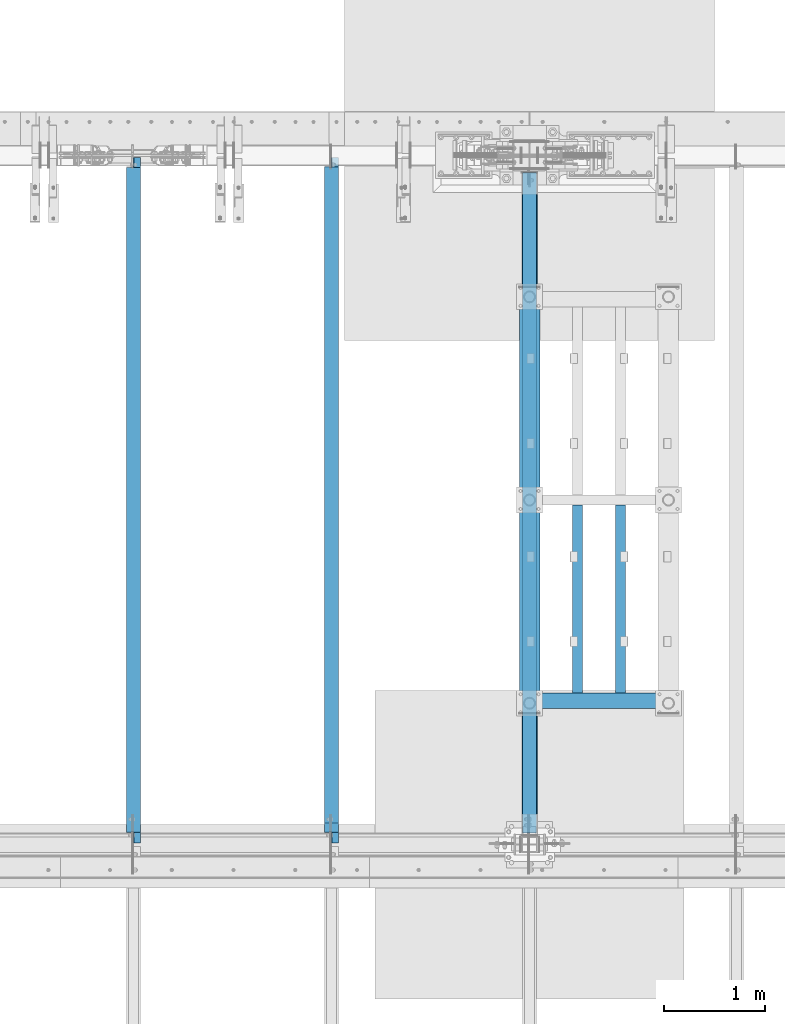
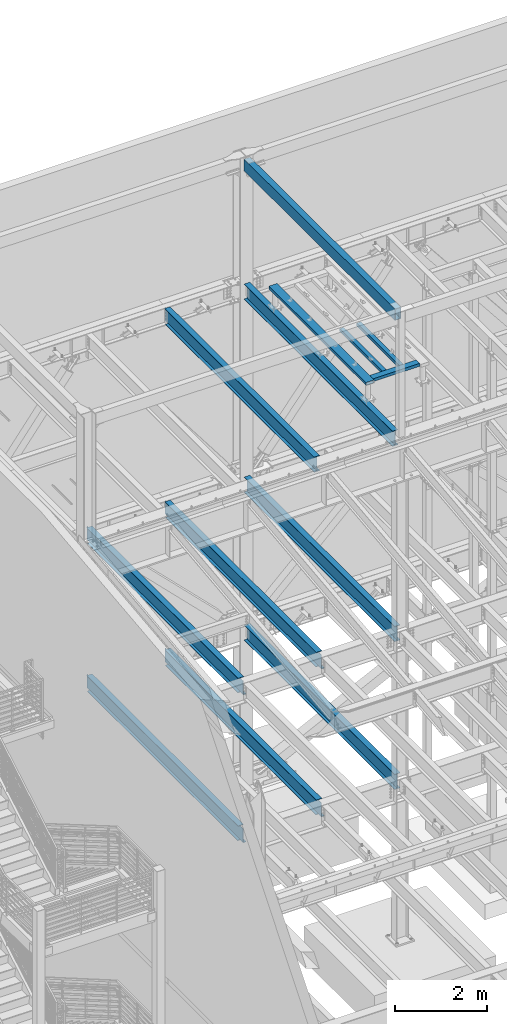
# One storey, part 767 of 1179: 13 beams, 10 elements without a shape of their own.
"""IFC2X3 building model written with IfcOpenShell, lengths in millimetres."""

from ifc_helpers import new_model, si_unit, frame, origin_with_axes, place, context, subcontext, project, spatial, faceted_brep, material, type_object, element, aggregate, save


model = new_model("IFC2X3")

# Units and contexts
model_context = context("Model", 3, precision=1e-05, world=origin_with_axes())
body_context = subcontext(model_context, "Body", "Model", "MODEL_VIEW")
ifc_project = project(units=[si_unit("LENGTHUNIT", "METRE", prefix="MILLI"), si_unit("AREAUNIT", "SQUARE_METRE"), si_unit("VOLUMEUNIT", "CUBIC_METRE"), si_unit("MASSUNIT", "GRAM", prefix="KILO"), si_unit("TIMEUNIT", "SECOND"), si_unit("PLANEANGLEUNIT", "RADIAN"), si_unit("SOLIDANGLEUNIT", "STERADIAN"), si_unit("THERMODYNAMICTEMPERATUREUNIT", "DEGREE_CELSIUS"), si_unit("LUMINOUSINTENSITYUNIT", "LUMEN")], contexts=[model_context])

# Site, building, storey
site_placement = place(None, origin_with_axes())
site = spatial("IfcSite", under=ifc_project, at=site_placement, CompositionType="ELEMENT")
building_placement = place(site_placement, origin_with_axes())
building = spatial("IfcBuilding", under=site, at=building_placement, Name="Undefined", CompositionType="ELEMENT")
storey_placement = place(building_placement, origin_with_axes())
storey = spatial("IfcBuildingStorey", under=building, at=storey_placement, Name="Undefined", CompositionType="ELEMENT", Elevation=0.0)

# Assembly, beam
assembly_1_placement = place(storey_placement, origin_with_axes())
assembly_1 = element("IfcElementAssembly", 1, at=assembly_1_placement, inside=storey, Name="BEAM", AssemblyPlace="NOTDEFINED", PredefinedType="RIGID_FRAME")
ifc_material_1 = material(Name="STEEL/A992")
beam_type_1 = type_object("IfcBeamType", Name="W16X31", PredefinedType="NOTDEFINED")
beam_1_placement = place(assembly_1_placement, frame((8280.4, 34391.6, 12917.4875), z_axis=(0.0, 0.0, 1.0), x_axis=(0.0, 1.0, 0.0)))
beam_1 = element("IfcBeam", 2, at=beam_1_placement, type_object=beam_type_1, material=ifc_material_1, Name="BEAM", ObjectType="W16X31", context=body_context, shape_type="Brep", body=[
    faceted_brep([(212.724999999999, -69.8499999999985, -201.612499999999), (212.724999999999, 69.8499999999985, -201.612499999999), (6637.33750000001, 69.8499999999985, -201.612499999999), (6637.33750000001, -69.8499999999985, -201.612499999999), (212.724999999999, -69.8499999999985, -190.5), (212.724999999999, -3.17499999999927, -190.5), (212.724999999999, -3.17499999999927, 190.5), (212.724999999999, -69.8499999999985, 190.5), (212.724999999999, -69.8499999999985, 201.612499999999), (212.724999999999, 69.8499999999985, 201.612499999999), (212.724999999999, 69.8499999999985, 190.5), (212.724999999999, 3.17499999999927, 190.5), (212.724999999999, 3.17499999999927, 162.664998864024), (212.724999999999, 3.17499999999927, -142.027500567505), (212.724999999999, 3.17499999999927, -190.5), (212.724999999999, 69.8499999999985, -190.5), (6637.33750000001, -69.8499999999985, -190.5), (6637.33750000001, -3.17499999999927, -190.5), (6637.33750000001, -3.17499999999927, 190.5), (6637.33750000001, -69.8499999999985, 190.5), (6637.33750000001, -69.8499999999985, 201.612499999999), (6637.33750000001, 69.8499999999985, 201.612499999999), (6637.33750000001, 69.8499999999985, 190.5), (6637.33750000001, 3.17499999999927, 190.5), (6637.33750000001, 3.17499999999927, -190.5), (6637.33750000001, 69.8499999999985, -190.5)], [[[0, 1, 2, 3]], [[0, 4, 5, 6, 7, 8, 9, 10, 11, 12, 13, 14, 15, 1]], [[5, 4, 16, 17]], [[6, 5, 17, 18]], [[7, 6, 18, 19]], [[8, 7, 19, 20]], [[9, 8, 20, 21]], [[10, 9, 21, 22]], [[11, 10, 22, 23]], [[14, 13, 12, 11, 23, 24]], [[15, 14, 24, 25]], [[1, 15, 25, 2]], [[24, 23, 22, 21, 20, 19, 18, 17, 16, 3, 2, 25]], [[4, 0, 3, 16]]]),
])
aggregate(assembly_1, [beam_1])

assembly_2_placement = place(storey_placement, origin_with_axes())
assembly_2 = element("IfcElementAssembly", 3, at=assembly_2_placement, inside=storey, Name="BEAM", AssemblyPlace="NOTDEFINED", PredefinedType="RIGID_FRAME")
beam_2_placement = place(assembly_2_placement, frame((6324.6, 34391.6, 12917.4875), z_axis=(0.0, 0.0, 1.0), x_axis=(0.0, 1.0, 0.0)))
beam_2 = element("IfcBeam", 4, at=beam_2_placement, type_object=beam_type_1, material=ifc_material_1, Name="BEAM", ObjectType="W16X31", context=body_context, shape_type="Brep", body=[
    faceted_brep([(212.724999999999, 69.8499999999985, -190.5), (212.724999999999, 3.17499999999927, -190.5), (6661.94375000001, 3.17499999999927, -190.5), (6661.94375000001, 69.8499999999985, -190.5), (212.724999999999, -3.17499999999927, -190.5), (212.724999999999, -69.8499999999985, -190.5), (6788.94375000001, -69.8499999999985, -190.5), (6788.94375000001, -3.17499999999927, -190.5), (212.724999999999, -69.8499999999985, -201.612499999999), (6788.94375000001, -69.8499999999985, -201.612499999999), (6788.94375000001, 3.17549991607666, -201.612499999999), (6788.94375000001, 3.17499999999927, -190.5), (6788.94375000001, 3.17499999999927, 163.512499999999), (6788.94375000001, -3.17499999999927, 163.512499999999), (6661.94375000001, 3.17549991607666, -201.612499999999), (212.724999999999, 69.8499999999985, -201.612499999999), (6661.94375000001, 69.8499999999985, -201.612499999999), (212.724999999999, -3.17499999999927, 190.5), (212.724999999999, -69.8499999999985, 190.5), (212.724999999999, -69.8499999999985, 201.612499999999), (212.724999999999, 69.8499999999985, 201.612499999999), (212.724999999999, 69.8499999999985, 190.5), (212.724999999999, 3.17499999999927, 190.5), (212.724999999999, 3.17499999999927, 162.664998864024), (212.724999999999, 3.17499999999927, -142.027500567505), (6696.86875000001, 69.8499999999985, 190.5), (6696.86875000001, 3.17499999999927, 190.5), (6696.86875000001, 3.17499999999927, 176.212499809264), (6697.8354799226, 3.17499999999927, 171.352420291218), (6700.58849382307, 3.17499999999927, 167.232243823064), (6704.70867029123, 3.17499999999927, 164.479229922586), (6709.56874980927, 3.17499999999927, 163.512499999999), (6697.8354799226, -3.17499999999927, 171.352420291218), (6696.86875000001, -3.17499999999927, 176.212499809264), (6700.58849382307, -3.17499999999927, 167.232243823064), (6704.70867029123, -3.17499999999927, 164.479229922586), (6709.56874980927, -3.17499999999927, 163.512499999999), (6696.86875000001, -3.17499999999927, 190.5), (6696.86875000001, -69.8499999999985, 190.5), (6696.86875000001, -69.8499999999985, 201.612499999999), (6696.86875000001, 69.8499999999985, 201.612499999999)], [[[0, 1, 2, 3]], [[4, 5, 6, 7]], [[5, 8, 9, 6]], [[7, 6, 9, 10, 11, 12, 13]], [[11, 10, 14, 2]], [[9, 8, 15, 16, 14, 10]], [[2, 14, 16, 3]], [[15, 0, 3, 16]], [[8, 5, 4, 17, 18, 19, 20, 21, 22, 23, 24, 1, 0, 15]], [[22, 21, 25, 26]], [[11, 2, 1, 24, 23, 22, 26, 27, 28, 29, 30, 31, 12]], [[32, 28, 27, 33]], [[34, 29, 28, 32]], [[35, 30, 29, 34]], [[36, 31, 30, 35]], [[13, 12, 31, 36]], [[35, 34, 32, 33, 37, 17, 4, 7, 13, 36]], [[18, 17, 37, 38]], [[19, 18, 38, 39]], [[20, 19, 39, 40]], [[21, 20, 40, 25]], [[39, 38, 37, 33, 27, 26, 25, 40]]]),
])
aggregate(assembly_2, [beam_2])

assembly_3_placement = place(storey_placement, origin_with_axes())
assembly_3 = element("IfcElementAssembly", 5, at=assembly_3_placement, inside=storey, Name="BEAM", AssemblyPlace="NOTDEFINED", PredefinedType="RIGID_FRAME")
beam_3_placement = place(assembly_3_placement, frame((8280.4, 34391.6, 7812.0875), z_axis=(0.0, 0.0, 1.0), x_axis=(0.0, 1.0, 0.0)))
beam_3 = element("IfcBeam", 6, at=beam_3_placement, type_object=beam_type_1, material=ifc_material_1, Name="BEAM", ObjectType="W16X31", context=body_context, shape_type="Brep", body=[
    faceted_brep([(115.887499999997, -69.8499999999985, -201.6125), (115.887499999997, 69.8499999999985, -201.6125), (6637.33750000001, 69.8499999999985, -201.612499999999), (6637.33750000001, -69.8499999999985, -201.612499999999), (115.887499999997, -69.8499999999985, -190.5), (115.887499999997, -3.17499999999927, -190.5), (115.887499999997, -3.17499999999927, 190.5), (115.887499999997, -69.8499999999985, 190.5), (115.887499999997, -69.8499999999985, 201.6125), (115.887499999997, 69.8499999999985, 201.6125), (115.887499999997, 69.8499999999985, 190.5), (115.887499999997, 3.17499999999927, 190.5), (115.887499999997, 3.17499999999927, 164.252489941818), (115.887499999997, 3.17499999999927, -142.027503290603), (115.887499999997, 3.17499999999927, -190.5), (115.887499999997, 69.8499999999985, -190.5), (6637.33750000001, -69.8499999999985, -190.5), (6637.33750000001, -3.17499999999927, -190.5), (6637.33750000001, -3.17499999999927, 190.5), (6637.33750000001, -69.8499999999985, 190.5), (6637.33750000001, -69.8499999999985, 201.612499999999), (6637.33750000001, 69.8499999999985, 201.612499999999), (6637.33750000001, 69.8499999999985, 190.5), (6637.33750000001, 3.17499999999927, 190.5), (6637.33750000001, 3.17499999999927, -190.5), (6637.33750000001, 69.8499999999985, -190.5)], [[[0, 1, 2, 3]], [[0, 4, 5, 6, 7, 8, 9, 10, 11, 12, 13, 14, 15, 1]], [[5, 4, 16, 17]], [[6, 5, 17, 18]], [[7, 6, 18, 19]], [[8, 7, 19, 20]], [[9, 8, 20, 21]], [[10, 9, 21, 22]], [[11, 10, 22, 23]], [[14, 13, 12, 11, 23, 24]], [[15, 14, 24, 25]], [[1, 15, 25, 2]], [[24, 23, 22, 21, 20, 19, 18, 17, 16, 3, 2, 25]], [[4, 0, 3, 16]]]),
])
aggregate(assembly_3, [beam_3])

assembly_4_placement = place(storey_placement, origin_with_axes())
assembly_4 = element("IfcElementAssembly", 7, at=assembly_4_placement, inside=storey, Name="BEAM", AssemblyPlace="NOTDEFINED", PredefinedType="RIGID_FRAME")
beam_4_placement = place(assembly_4_placement, frame((6324.6, 34391.6, 7812.0875), z_axis=(0.0, 0.0, 1.0), x_axis=(0.0, 1.0, 0.0)))
beam_4 = element("IfcBeam", 8, at=beam_4_placement, type_object=beam_type_1, material=ifc_material_1, Name="BEAM", ObjectType="W16X31", context=body_context, shape_type="Brep", body=[
    faceted_brep([(104.775000190733, -3.17499999999927, 166.6875), (104.775000190733, 3.17497120592088, 166.6875), (17.4624999999942, 3.17499999999927, 166.6875), (17.4624999999942, -3.17499999999927, 166.6875), (109.63507970878, -3.17499999999927, 167.654229922588), (109.63507970878, 3.17497058299341, 167.654229922588), (113.755256176933, -3.17499999999927, 170.407243823066), (113.755256176933, 3.17496880904946, 170.407243823066), (116.508270077407, -3.17499999999927, 174.52742029122), (116.508270077407, 3.17496615415439, 174.52742029122), (117.474999999999, -3.17499999999927, 179.387499809265), (117.474999999999, 3.17496302249128, 179.387499809265), (117.474999999999, -69.8499999999985, 201.6125), (117.474999999999, 69.8499999999985, 201.6125), (117.474999999999, 69.8499999999985, 190.5), (117.474999999999, 3.17499999999927, 190.5), (117.474999999999, -3.17499999999927, 190.5), (117.474999999999, -69.8499999999985, 190.5), (6660.35625, 3.17499999999927, -190.5), (6660.35625, 69.8500000000004, -190.5), (144.462499999994, 69.8499999999985, -190.5), (144.462499999994, 3.17549991607666, -190.5), (17.4624999999942, -3.17499999999927, -190.5), (17.4624999999942, -69.8499999999985, -190.5), (6787.35625, -69.8500000000004, -190.5), (6787.35625, -3.17499999999927, -190.5), (17.4624999999942, -69.8499999999985, -201.6125), (6787.35625, -69.8500000000004, -201.6125), (6660.35625, 69.8500000000004, -201.6125), (6660.35625, 3.17549991607484, -201.6125), (6787.35625, 3.17549991607484, -201.6125), (17.4624999999942, 3.17549991607666, -201.6125), (144.462499999994, 3.17549991607666, -201.6125), (144.462499999994, 69.8499999999985, -201.6125), (17.4624999999942, 3.17499999999927, -190.5), (6787.35625, 3.17499999999927, -190.5), (6787.35625, 3.17499999999927, 157.1625), (6787.35625, -3.17499999999927, 157.1625), (6700.04374980927, 3.17499999999927, 157.1625), (6700.04374980927, -3.17499999999927, 157.1625), (6695.18367029123, 3.17499999999927, 158.129229922588), (6695.18367029123, -3.17499999999927, 158.129229922588), (6691.06349382307, 3.17499999999927, 160.882243823066), (6691.06349382307, -3.17499999999927, 160.882243823066), (6688.31047992259, 3.17499999999927, 165.00242029122), (6688.31047992259, -3.17499999999927, 165.00242029122), (6687.34375000001, 3.17499999999927, 169.862499809266), (6687.34375000001, -3.17499999999927, 169.862499809266), (6687.34375000001, -69.8500000000004, 201.6125), (6687.34375000001, -69.8500000000004, 190.5), (6687.34375000001, -3.17499999999927, 190.5), (6687.34375000001, 3.17499999999927, 190.5), (6687.34375000001, 69.8500000000004, 190.5), (6687.34375000001, 69.8500000000004, 201.6125)], [[[0, 1, 2, 3]], [[4, 5, 1, 0]], [[6, 7, 5, 4]], [[8, 9, 7, 6]], [[10, 11, 9, 8]], [[12, 13, 14, 15, 11, 10, 16, 17]], [[18, 19, 20, 21]], [[22, 23, 24, 25]], [[23, 26, 27, 24]], [[28, 29, 30, 27, 26, 31, 32, 33]], [[21, 32, 31, 34]], [[20, 33, 32, 21]], [[19, 28, 33, 20]], [[18, 29, 28, 19]], [[35, 30, 29, 18]], [[25, 24, 27, 30, 35, 36, 37]], [[37, 36, 38, 39]], [[39, 38, 40, 41]], [[41, 40, 42, 43]], [[43, 42, 44, 45]], [[45, 44, 46, 47]], [[48, 49, 50, 47, 46, 51, 52, 53]], [[49, 48, 12, 17]], [[50, 49, 17, 16]], [[8, 6, 4, 0, 3, 22, 25, 37, 39, 41, 43, 45, 47, 50, 16, 10]], [[34, 31, 26, 23, 22, 3, 2]], [[51, 46, 44, 42, 40, 38, 36, 35, 18, 21, 34, 2, 1, 5, 7, 9, 11, 15]], [[52, 51, 15, 14]], [[53, 52, 14, 13]], [[48, 53, 13, 12]]]),
])
aggregate(assembly_4, [beam_4])

assembly_5_placement = place(storey_placement, origin_with_axes())
assembly_5 = element("IfcElementAssembly", 9, at=assembly_5_placement, inside=storey, Name="BEAM", AssemblyPlace="NOTDEFINED", PredefinedType="RIGID_FRAME")
beam_5_placement = place(assembly_5_placement, frame((4368.8, 34391.6, 7812.0875), z_axis=(0.0, 0.0, 1.0), x_axis=(0.0, 1.0, 0.0)))
beam_5 = element("IfcBeam", 10, at=beam_5_placement, type_object=beam_type_1, material=ifc_material_1, Name="BEAM", ObjectType="W16X31", context=body_context, shape_type="Brep", body=[
    faceted_brep([(104.775000190733, -3.17499999999927, 166.6875), (104.775000190733, 3.17497120592088, 166.6875), (17.4624999999942, 3.17499999999927, 166.6875), (17.4624999999942, -3.17499999999927, 166.6875), (109.63507970878, -3.17499999999927, 167.654229922588), (109.63507970878, 3.17497058299341, 167.654229922588), (113.755256176933, -3.17499999999927, 170.407243823066), (113.755256176933, 3.17496880904946, 170.407243823066), (116.508270077407, -3.17499999999927, 174.52742029122), (116.508270077407, 3.17496615415439, 174.52742029122), (117.474999999999, -3.17499999999927, 179.387499809265), (117.474999999999, 3.17496302249128, 179.387499809265), (117.474999999999, -69.8499999999985, 201.6125), (117.474999999999, 69.8499999999985, 201.6125), (117.474999999999, 69.8499999999985, 190.5), (117.474999999999, 3.17499999999927, 190.5), (117.474999999999, -3.17499999999927, 190.5), (117.474999999999, -69.8499999999985, 190.5), (6660.35625, 3.17499999999927, -190.5), (6660.35625, 69.8500000000004, -190.5), (144.462499999994, 69.8499999999985, -190.5), (144.462499999994, 3.17549991607666, -190.5), (17.4624999999942, -3.17499999999927, -190.5), (17.4624999999942, -69.8499999999985, -190.5), (6787.35625, -69.8500000000004, -190.5), (6787.35625, -3.17499999999927, -190.5), (17.4624999999942, -69.8499999999985, -201.6125), (6787.35625, -69.8500000000004, -201.6125), (6660.35625, 69.8500000000004, -201.6125), (6660.35625, 3.1754070527486, -201.6125), (6787.35625, 3.1754070527486, -201.6125), (17.4624999999942, 3.17549991607666, -201.6125), (144.462499999994, 3.17549991607666, -201.6125), (144.462499999994, 69.8499999999985, -201.6125), (17.4624999999942, 3.17499999999927, -190.5), (6787.35625, 3.17499999999927, -190.5), (6787.35625, 3.17499999999927, 157.1625), (6787.35625, -3.17499999999927, 157.1625), (6700.04374980927, 3.17499999999927, 157.1625), (6700.04374980927, -3.17499999999927, 157.1625), (6695.18367029123, 3.17499999999927, 158.129229922588), (6695.18367029123, -3.17499999999927, 158.129229922588), (6691.06349382307, 3.17499999999927, 160.882243823066), (6691.06349382307, -3.17499999999927, 160.882243823066), (6688.31047992259, 3.17499999999927, 165.00242029122), (6688.31047992259, -3.17499999999927, 165.00242029122), (6687.34375000001, 3.17499999999927, 169.862499809266), (6687.34375000001, -3.17499999999927, 169.862499809266), (6687.34375000001, -69.8500000000004, 201.6125), (6687.34375000001, -69.8500000000004, 190.5), (6687.34375000001, -3.17499999999927, 190.5), (6687.34375000001, 3.17499999999927, 190.5), (6687.34375000001, 69.8500000000004, 190.5), (6687.34375000001, 69.8500000000004, 201.6125)], [[[0, 1, 2, 3]], [[4, 5, 1, 0]], [[6, 7, 5, 4]], [[8, 9, 7, 6]], [[10, 11, 9, 8]], [[12, 13, 14, 15, 11, 10, 16, 17]], [[18, 19, 20, 21]], [[22, 23, 24, 25]], [[23, 26, 27, 24]], [[28, 29, 30, 27, 26, 31, 32, 33]], [[21, 32, 31, 34]], [[20, 33, 32, 21]], [[19, 28, 33, 20]], [[18, 29, 28, 19]], [[35, 30, 29, 18]], [[25, 24, 27, 30, 35, 36, 37]], [[37, 36, 38, 39]], [[39, 38, 40, 41]], [[41, 40, 42, 43]], [[43, 42, 44, 45]], [[45, 44, 46, 47]], [[48, 49, 50, 47, 46, 51, 52, 53]], [[49, 48, 12, 17]], [[50, 49, 17, 16]], [[8, 6, 4, 0, 3, 22, 25, 37, 39, 41, 43, 45, 47, 50, 16, 10]], [[34, 31, 26, 23, 22, 3, 2]], [[51, 46, 44, 42, 40, 38, 36, 35, 18, 21, 34, 2, 1, 5, 7, 9, 11, 15]], [[52, 51, 15, 14]], [[53, 52, 14, 13]], [[48, 53, 13, 12]]]),
])
aggregate(assembly_5, [beam_5])

assembly_6_placement = place(storey_placement, origin_with_axes())
assembly_6 = element("IfcElementAssembly", 11, at=assembly_6_placement, inside=storey, Name="BEAM", AssemblyPlace="NOTDEFINED", PredefinedType="RIGID_FRAME")
beam_6_placement = place(assembly_6_placement, frame((8280.4, 34396.3625, 3900.4875), z_axis=(0.0, 0.0, 1.0), x_axis=(0.0, 1.0, 0.0)))
beam_6 = element("IfcBeam", 12, at=beam_6_placement, type_object=beam_type_1, material=ifc_material_1, Name="BEAM", ObjectType="W16X31", context=body_context, shape_type="Brep", body=[
    faceted_brep([(111.124998253748, -69.8499999999785, -201.6125), (111.125001746244, 69.8500000000222, -201.6125), (6632.57500174626, 69.8500000012627, -201.6125), (6632.57499825375, -69.849999998738, -201.6125), (111.124998253748, -69.8499999999785, -190.5), (111.124999920619, -3.17499999997744, -190.5), (111.124999920619, -3.17499999997744, 190.5), (111.124998253748, -69.8499999999785, 190.5), (111.124998253748, -69.8499999999785, 201.6125), (111.125001746244, 69.8500000000222, 201.6125), (111.125001746244, 69.8500000000222, 190.5), (111.125000079373, 3.1750000000211, 190.5), (111.125000079373, 3.1750000000211, 164.252489942032), (111.125000079373, 3.1750000000211, -142.027503290585), (111.125000079373, 3.1750000000211, -190.5), (111.125001746244, 69.8500000000222, -190.5), (6632.57499825375, -69.849999998738, -190.5), (6632.57499992063, -3.17499999873871, -190.5), (6632.57499992063, -3.17499999873871, 190.5), (6632.57499825375, -69.849999998738, 190.5), (6632.57499825375, -69.849999998738, 201.6125), (6632.57500174626, 69.8500000012627, 201.6125), (6632.57500174626, 69.8500000012627, 190.5), (6632.57500007938, 3.17500000126165, 190.5), (6632.57500007938, 3.17500000126165, -190.5), (6632.57500174626, 69.8500000012627, -190.5)], [[[0, 1, 2, 3]], [[0, 4, 5, 6, 7, 8, 9, 10, 11, 12, 13, 14, 15, 1]], [[5, 4, 16, 17]], [[6, 5, 17, 18]], [[7, 6, 18, 19]], [[8, 7, 19, 20]], [[9, 8, 20, 21]], [[10, 9, 21, 22]], [[11, 10, 22, 23]], [[14, 13, 12, 11, 23, 24]], [[15, 14, 24, 25]], [[1, 15, 25, 2]], [[24, 23, 22, 21, 20, 19, 18, 17, 16, 3, 2, 25]], [[4, 0, 3, 16]]]),
])
aggregate(assembly_6, [beam_6])

assembly_7_placement = place(storey_placement, origin_with_axes())
assembly_7 = element("IfcElementAssembly", 13, at=assembly_7_placement, inside=storey, Name="BEAM", AssemblyPlace="NOTDEFINED", PredefinedType="RIGID_FRAME")
beam_7_placement = place(assembly_7_placement, frame((6324.59996643066, 34391.6, 3900.4875), z_axis=(0.0, 0.0, 1.0), x_axis=(0.0, 1.0, 0.0)))
beam_7 = element("IfcBeam", 14, at=beam_7_placement, type_object=beam_type_1, material=ifc_material_1, Name="BEAM", ObjectType="W16X31", context=body_context, shape_type="Brep", body=[
    faceted_brep([(6687.34375000001, -69.8500000000004, 201.6125), (6687.34375000001, -69.8500000000004, 190.5), (6687.34375000001, -3.17499999999927, 190.5), (6687.34375174629, -3.17499999872598, 176.212499809265), (6687.3437517463, 3.17494718995658, 176.212499809265), (6687.34375000001, 3.17499999999927, 190.5), (6687.34375000001, 69.8500000000004, 190.5), (6687.34375000001, 69.8500000000004, 201.6125), (6688.31048166887, -3.17499999872598, 171.352420291219), (6688.31048166887, 3.17500000127438, 171.352420291219), (6691.06349556935, -3.17499999872598, 167.232243823065), (6691.06349556935, 3.17500000127438, 167.232243823065), (6695.18367203751, -3.17499999872416, 164.479229922587), (6695.18367203751, 3.1750000012762, 164.479229922587), (6700.04375155555, -3.17499999872416, 163.512499999999), (6700.04375155555, 3.1750000012762, 163.512499999999), (6787.35624992065, -3.17499999870779, 163.512499999999), (6787.35625007939, 3.17500000129257, 163.512499999999), (126.206251745432, -69.8499999999767, 201.6125), (126.206251745396, 69.850000000024, 201.6125), (126.206251745396, 69.850000000024, 190.5), (126.206251745418, 3.17500000002292, 190.5), (126.206251745411, 3.1749547025629, 182.562499809265), (126.206251745411, -3.17499999997744, 182.562499809265), (126.206251745411, -3.17499999997744, 190.5), (126.206251745432, -69.8499999999767, 190.5), (125.239521822819, 3.17495834479632, 177.70242029122), (125.239521822827, -3.17499999997563, 177.70242029122), (122.486507922345, 3.17496143253265, 173.582243823066), (122.486507922345, -3.17499999997744, 173.582243823066), (118.366331454192, 3.17496349569046, 170.829229922588), (118.366331454192, -3.17499999997926, 170.829229922588), (113.506251936145, 3.17496422017757, 169.8625), (113.506251936145, -3.17499999997744, 169.8625), (18.2562514952835, 3.17499999999927, 169.8625), (18.2562514952835, -3.17499999999927, 169.8625), (18.2562500000006, 3.17500000000291, -190.5), (18.2562500793938, 3.17558455032122, -201.6125), (18.2562500000006, -69.8499999999985, -201.612499999999), (18.2562500000006, -69.8499999999985, -190.5), (18.2562500000006, -3.17500000000291, -190.5), (145.256250079394, 3.17558137532069, -190.5), (145.256250079394, 3.17558137532069, -201.6125), (145.256250000001, 69.8499999999985, -190.5), (145.256250000001, 69.8499999999985, -201.612499999999), (6660.35625, 3.17499999999927, -190.5), (6660.35625, 69.8500000000004, -190.5), (6660.35625, 69.8500000000004, -201.6125), (6660.3562500794, 3.17555155085756, -201.6125), (6787.35625, 3.17499999999927, -190.5), (6787.35625, 3.17549991607484, -201.6125), (6787.35625, -69.8500000000004, -201.6125), (6787.35625, -69.8500000000004, -190.5), (6787.35625, -3.17499999999927, -190.5)], [[[0, 1, 2, 3, 4, 5, 6, 7]], [[8, 9, 4, 3]], [[10, 11, 9, 8]], [[12, 13, 11, 10]], [[14, 15, 13, 12]], [[16, 17, 15, 14]], [[18, 19, 20, 21, 22, 23, 24, 25]], [[23, 22, 26, 27]], [[27, 26, 28, 29]], [[29, 28, 30, 31]], [[31, 30, 32, 33]], [[33, 32, 34, 35]], [[36, 37, 38, 39, 40, 35, 34]], [[41, 42, 37, 36]], [[43, 44, 42, 41]], [[45, 46, 43, 41]], [[46, 47, 44, 43]], [[45, 48, 47, 46]], [[49, 50, 48, 45]], [[51, 38, 37, 42, 44, 47, 48, 50]], [[39, 38, 51, 52]], [[40, 39, 52, 53]], [[27, 29, 31, 33, 35, 40, 53, 16, 14, 12, 10, 8, 3, 2, 24, 23]], [[2, 1, 25, 24]], [[1, 0, 18, 25]], [[0, 7, 19, 18]], [[7, 6, 20, 19]], [[6, 5, 21, 20]], [[49, 45, 41, 36, 34, 32, 30, 28, 26, 22, 21, 5, 4, 9, 11, 13, 15, 17]], [[53, 52, 51, 50, 49, 17, 16]]]),
])
aggregate(assembly_7, [beam_7])

assembly_8_placement = place(storey_placement, origin_with_axes())
assembly_8 = element("IfcElementAssembly", 15, at=assembly_8_placement, inside=storey, Name="BEAM", AssemblyPlace="NOTDEFINED", PredefinedType="RIGID_FRAME")
beam_8_placement = place(assembly_8_placement, frame((4368.8, 34391.6, 3900.4875), z_axis=(0.0, 0.0, 1.0), x_axis=(0.0, 1.0, 0.0)))
beam_8 = element("IfcBeam", 16, at=beam_8_placement, type_object=beam_type_1, material=ifc_material_1, Name="BEAM", ObjectType="W16X31", context=body_context, shape_type="Brep", body=[
    faceted_brep([(113.506251936145, -3.17499999997744, 169.8625), (113.506251936145, 3.17496422017757, 169.8625), (18.2562514952835, 3.17499999999927, 169.8625), (18.2562514952835, -3.17499999999927, 169.8625), (118.366331454192, -3.17499999997926, 170.829229922588), (118.366331454192, 3.17496349569046, 170.829229922588), (122.486507922345, -3.17499999997744, 173.582243823066), (122.486507922345, 3.17496143253265, 173.582243823066), (125.239521822827, -3.17499999997563, 177.70242029122), (125.239521822819, 3.17495834479632, 177.70242029122), (126.206251745411, -3.17499999997744, 182.562499809265), (126.206251745411, 3.1749547025629, 182.562499809265), (126.206251745432, -69.8499999999767, 201.6125), (126.206251745396, 69.850000000024, 201.6125), (126.206251745396, 69.850000000024, 190.5), (126.206251745418, 3.17500000002292, 190.5), (126.206251745411, -3.17499999997744, 190.5), (126.206251745432, -69.8499999999767, 190.5), (6660.35625, 3.17499999999927, -190.5), (6660.35625, 69.8500000000004, -190.5), (145.256250000001, 69.8499999999985, -190.5), (145.256250079394, 3.17558137532069, -190.5), (18.2562500000006, -3.17500000000291, -190.5), (18.2562500000006, -69.8499999999985, -190.5), (6787.35625, -69.8500000000004, -190.5), (6787.35625, -3.17499999999927, -190.5), (18.2562500000006, -69.8499999999985, -201.612499999999), (6787.35625, -69.8500000000004, -201.6125), (6660.35625, 69.8500000000004, -201.6125), (6660.35625007939, 3.17532701270648, -201.6125), (6787.35625007939, 3.17532383770595, -201.6125), (18.2562500793938, 3.17558455032122, -201.6125), (145.256250079394, 3.17558137532069, -201.6125), (145.256250000001, 69.8499999999985, -201.612499999999), (18.2562500000006, 3.17500000000291, -190.5), (6787.35625, 3.17499999999927, -190.5), (6787.35625007939, 3.17500000129257, 163.512499999999), (6787.35624992065, -3.17499999870779, 163.512499999999), (6700.04375155555, 3.1750000012762, 163.512499999999), (6700.04375155555, -3.17499999872416, 163.512499999999), (6695.18367203751, 3.1750000012762, 164.479229922587), (6695.18367203751, -3.17499999872416, 164.479229922587), (6691.06349556935, 3.17500000127438, 167.232243823065), (6691.06349556935, -3.17499999872598, 167.232243823065), (6688.31048166887, 3.17500000127438, 171.352420291219), (6688.31048166887, -3.17499999872598, 171.352420291219), (6687.34375174628, 3.17500000127438, 176.212499809265), (6687.34375174629, -3.17499999872598, 176.212499809265), (6687.34375000001, -69.8500000000004, 201.6125), (6687.34375000001, -69.8500000000004, 190.5), (6687.34375000001, -3.17499999999927, 190.5), (6687.34375000001, 3.17499999999927, 190.5), (6687.34375000001, 69.8500000000004, 190.5), (6687.34375000001, 69.8500000000004, 201.6125)], [[[0, 1, 2, 3]], [[4, 5, 1, 0]], [[6, 7, 5, 4]], [[8, 9, 7, 6]], [[10, 11, 9, 8]], [[12, 13, 14, 15, 11, 10, 16, 17]], [[18, 19, 20, 21]], [[22, 23, 24, 25]], [[23, 26, 27, 24]], [[28, 29, 30, 27, 26, 31, 32, 33]], [[21, 32, 31, 34]], [[20, 33, 32, 21]], [[19, 28, 33, 20]], [[18, 29, 28, 19]], [[35, 30, 29, 18]], [[25, 24, 27, 30, 35, 36, 37]], [[37, 36, 38, 39]], [[39, 38, 40, 41]], [[41, 40, 42, 43]], [[43, 42, 44, 45]], [[45, 44, 46, 47]], [[48, 49, 50, 47, 46, 51, 52, 53]], [[49, 48, 12, 17]], [[50, 49, 17, 16]], [[8, 6, 4, 0, 3, 22, 25, 37, 39, 41, 43, 45, 47, 50, 16, 10]], [[34, 31, 26, 23, 22, 3, 2]], [[51, 46, 44, 42, 40, 38, 36, 35, 18, 21, 34, 2, 1, 5, 7, 9, 11, 15]], [[52, 51, 15, 14]], [[53, 52, 14, 13]], [[48, 53, 13, 12]]]),
])
aggregate(assembly_8, [beam_8])

# Assembly, beams
assembly_9_placement = place(storey_placement, origin_with_axes())
assembly_9 = element("IfcElementAssembly", 17, at=assembly_9_placement, inside=storey, Name="FRAME", AssemblyPlace="NOTDEFINED", PredefinedType="RIGID_FRAME")
ifc_material_2 = material()
beam_type_2 = type_object("IfcBeamType", Name="HSS4X3X1/4", PredefinedType="NOTDEFINED")
beam_9_placement = place(assembly_9_placement, frame((9177.86666666667, 35889.5344873485, 13722.35), z_axis=(1.0, 0.0, 0.0), x_axis=(0.0, 1.0, 0.0)))
beam_9 = element("IfcBeam", 18, at=beam_9_placement, type_object=beam_type_2, material=ifc_material_2, Name="BEAM", ObjectType="HSS4X3X1/4", context=body_context, shape_type="Brep", body=[
    faceted_brep([(0.0, 31.75, -44.4499999999971), (0.0, -31.75, -44.4499999999971), (1854.2, -31.75, -44.4500000000007), (1854.2, 31.75, -44.4500000000007), (0.0, -31.75, 44.4499999999971), (1854.2, -31.75, 44.4500000000007), (0.0, 31.75, 44.4499999999971), (1854.2, 31.75, 44.4500000000007), (0.0, 38.0999999999985, -50.8000000000002), (1.45519152283669e-11, 38.1000000000004, 50.8000000000002), (1854.2, 38.1000000000004, 50.7999999999993), (1854.2, 38.1000000000004, -50.7999999999993), (0.0, -38.0999999999985, 50.8000000000002), (1854.2, -38.1000000000004, 50.7999999999993), (0.0, -38.0999999999985, -50.8000000000002), (1854.2, -38.1000000000004, -50.7999999999993)], [[[0, 1, 2, 3]], [[1, 4, 5, 2]], [[4, 6, 7, 5]], [[6, 0, 3, 7]], [[8, 9, 10, 11]], [[9, 12, 13, 10]], [[12, 14, 15, 13]], [[14, 8, 11, 15]], [[13, 15, 11, 10], [5, 7, 3, 2]], [[14, 12, 9, 8], [6, 4, 1, 0]]]),
])
beam_10_placement = place(assembly_9_placement, frame((8754.53333333333, 35889.5344873485, 13722.35), z_axis=(1.0, 0.0, 0.0), x_axis=(0.0, 1.0, 0.0)))
beam_10 = element("IfcBeam", 19, at=beam_10_placement, type_object=beam_type_2, material=ifc_material_2, Name="BEAM", ObjectType="HSS4X3X1/4", context=body_context, shape_type="Brep", body=[
    faceted_brep([(0.0, 31.75, -44.4499999999971), (0.0, -31.75, -44.4499999999971), (1854.2, -31.75, -44.4500000000007), (1854.2, 31.75, -44.4500000000007), (0.0, -31.75, 44.4499999999971), (1854.2, -31.75, 44.4500000000007), (0.0, 31.75, 44.4499999999971), (1854.2, 31.75, 44.4500000000007), (0.0, 38.0999999999985, -50.8000000000002), (1.45519152283669e-11, 38.1000000000004, 50.8000000000002), (1854.2, 38.1000000000004, 50.7999999999993), (1854.2, 38.1000000000004, -50.7999999999993), (0.0, -38.0999999999985, 50.8000000000002), (1854.2, -38.1000000000004, 50.7999999999993), (0.0, -38.0999999999985, -50.8000000000002), (1854.2, -38.1000000000004, -50.7999999999993)], [[[0, 1, 2, 3]], [[1, 4, 5, 2]], [[4, 6, 7, 5]], [[6, 0, 3, 7]], [[8, 9, 10, 11]], [[9, 12, 13, 10]], [[12, 14, 15, 13]], [[14, 8, 11, 15]], [[13, 15, 11, 10], [5, 7, 3, 2]], [[14, 12, 9, 8], [6, 4, 1, 0]]]),
])
beam_type_3 = type_object("IfcBeamType", Name="HSS6X3X1/4", PredefinedType="NOTDEFINED")
beam_11_placement = place(assembly_9_placement, frame((8382.0, 35813.3344873485, 13722.35), z_axis=(0.0, -1.0, 0.0), x_axis=(1.0, 0.0, 0.0)))
beam_11 = element("IfcBeam", 20, at=beam_11_placement, type_object=beam_type_3, material=ifc_material_2, Name="BEAM", ObjectType="HSS6X3X1/4", context=body_context, shape_type="Brep", body=[
    faceted_brep([(0.0, 31.75, -69.8499999999985), (0.0, -31.75, -69.8499999999985), (1168.4, -31.75, -69.8499999999985), (1168.4, 31.75, -69.8499999999985), (0.0, -31.75, 69.8499999999985), (1168.4, -31.75, 69.8499999999985), (0.0, 31.75, 69.8499999999985), (1168.4, 31.75, 69.8499999999985), (0.0, 38.0999999999985, -76.1999999999998), (0.0, 38.0999999999985, 76.1999999999998), (1168.4, 38.1000000000004, 76.1999999999971), (1168.4, 38.1000000000004, -76.1999999999971), (0.0, -38.0999999999985, 76.1999999999998), (1168.4, -38.1000000000004, 76.1999999999971), (0.0, -38.0999999999985, -76.1999999999998), (1168.4, -38.1000000000004, -76.1999999999971)], [[[0, 1, 2, 3]], [[1, 4, 5, 2]], [[4, 6, 7, 5]], [[6, 0, 3, 7]], [[8, 9, 10, 11]], [[9, 12, 13, 10]], [[12, 14, 15, 13]], [[14, 8, 11, 15]], [[13, 15, 11, 10], [5, 7, 3, 2]], [[14, 12, 9, 8], [6, 4, 1, 0]]]),
])
beam_type_4 = type_object("IfcBeamType", Name="HSS8X3X1/4", PredefinedType="NOTDEFINED")
beam_12_placement = place(assembly_9_placement, frame((8280.4, 35686.3344873485, 13722.35), z_axis=(1.0, 0.0, 0.0), x_axis=(0.0, 1.0, 0.0)))
beam_12 = element("IfcBeam", 21, at=beam_12_placement, type_object=beam_type_4, material=ifc_material_2, Name="FRAME", ObjectType="HSS8X3X1/4", context=body_context, shape_type="Brep", body=[
    faceted_brep([(4.76249999999709, 31.75, -95.25), (4.76249999999709, -31.75, -95.25), (4211.6375, -31.75, -95.25), (4211.6375, 31.75, -95.25), (4.76249999999709, -31.75, 95.25), (4211.6375, -31.75, 95.25), (4.76249999999709, 31.75, 95.25), (4211.6375, 31.75, 95.25), (4.76249999999709, 38.1000000000004, -101.599999999999), (4.76249999999709, 38.1000000000004, 101.599999999999), (4211.6375, 38.1000000000004, 101.6), (4211.6375, 38.1000000000004, -101.6), (4.76249999999709, -38.1000000000004, 101.599999999999), (4211.6375, -38.1000000000004, 101.6), (4.76249999999709, -38.1000000000004, -101.599999999999), (4211.6375, -38.1000000000004, -101.6)], [[[0, 1, 2, 3]], [[1, 4, 5, 2]], [[4, 6, 7, 5]], [[6, 0, 3, 7]], [[8, 9, 10, 11]], [[9, 12, 13, 10]], [[12, 14, 15, 13]], [[14, 8, 11, 15]], [[13, 15, 11, 10], [5, 7, 3, 2]], [[14, 12, 9, 8], [6, 4, 1, 0]]]),
])
aggregate(assembly_9, [beam_9, beam_10, beam_11, beam_12])

# Assembly, beam
assembly_10_placement = place(storey_placement, origin_with_axes())
assembly_10 = element("IfcElementAssembly", 22, at=assembly_10_placement, inside=storey, Name="BEAM", AssemblyPlace="NOTDEFINED", PredefinedType="RIGID_FRAME")
beam_type_5 = type_object("IfcBeamType", Name="HSS12X6X3/8", PredefinedType="NOTDEFINED")
beam_13_placement = place(assembly_10_placement, frame((8280.4, 34480.5, 16275.05), z_axis=(0.0, 0.0, 1.0), x_axis=(0.0, 1.0, 0.0)))
beam_13 = element("IfcBeam", 23, at=beam_13_placement, type_object=beam_type_5, material=ifc_material_2, Name="BEAM", ObjectType="HSS12X6X3/8", context=body_context, shape_type="Brep", body=[
    faceted_brep([(4.76249999999709, 66.6749999999993, -142.875), (4.76249999999709, -66.6749999999993, -142.875), (6543.67500000002, -66.6749999999993, -142.875), (6543.67500000002, 66.6749999999993, -142.875), (4.76249999999709, -66.6749999999993, 142.875000000002), (6543.67500000002, -66.6749999999993, 142.875000000002), (4.76249999999709, 66.6749999999993, 142.875000000002), (6543.67500000002, 66.6749999999993, 142.875000000002), (4.76249999999709, 76.2000000000007, -152.4), (4.76249999999709, 76.2000000000007, 152.4), (6543.67500000002, 76.2000000000007, 152.4), (6543.67500000002, 76.2000000000007, -152.4), (4.76249999999709, -76.2000000000007, 152.4), (6543.67500000002, -76.2000000000007, 152.4), (4.76249999999709, -76.2000000000007, -152.4), (6543.67500000002, -76.2000000000007, -152.4)], [[[0, 1, 2, 3]], [[1, 4, 5, 2]], [[4, 6, 7, 5]], [[6, 0, 3, 7]], [[8, 9, 10, 11]], [[9, 12, 13, 10]], [[12, 14, 15, 13]], [[14, 8, 11, 15]], [[13, 15, 11, 10], [5, 7, 3, 2]], [[14, 12, 9, 8], [6, 4, 1, 0]]]),
])
aggregate(assembly_10, [beam_13])

save(model, "model.ifc")
